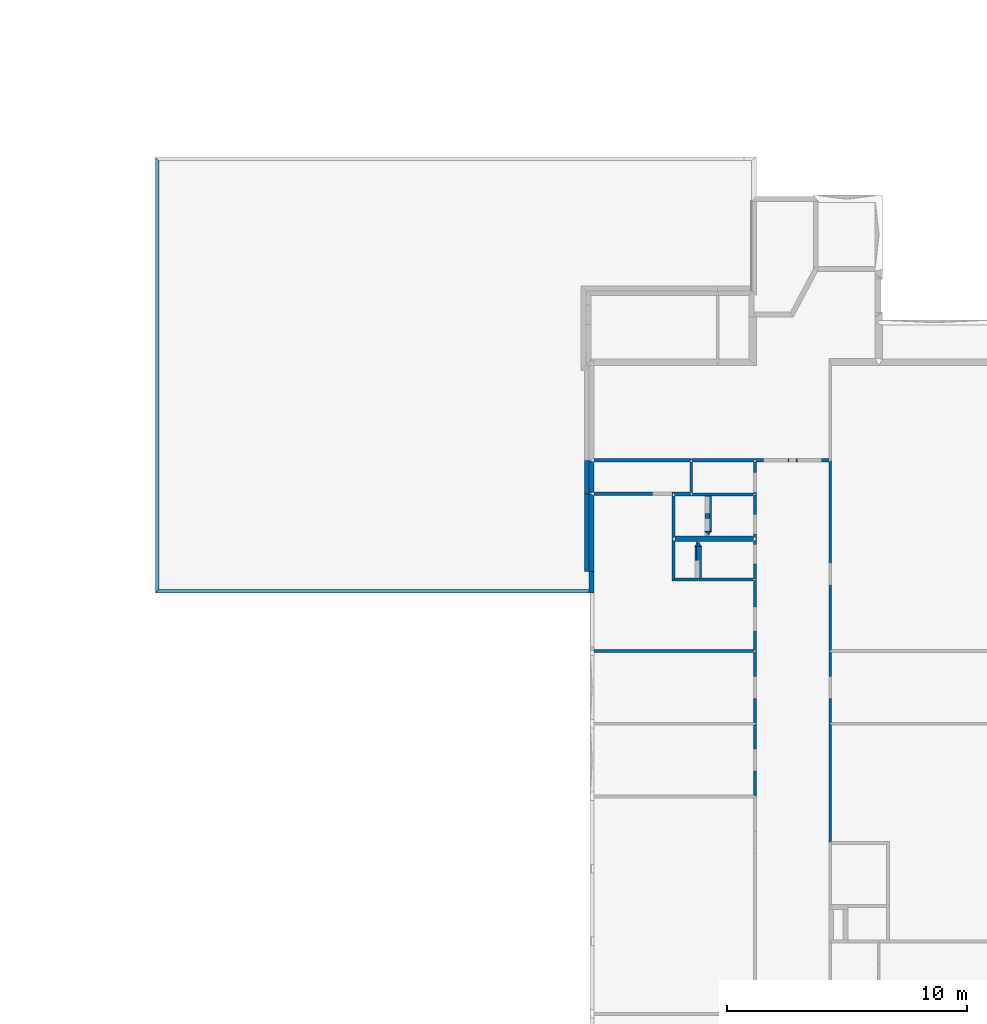
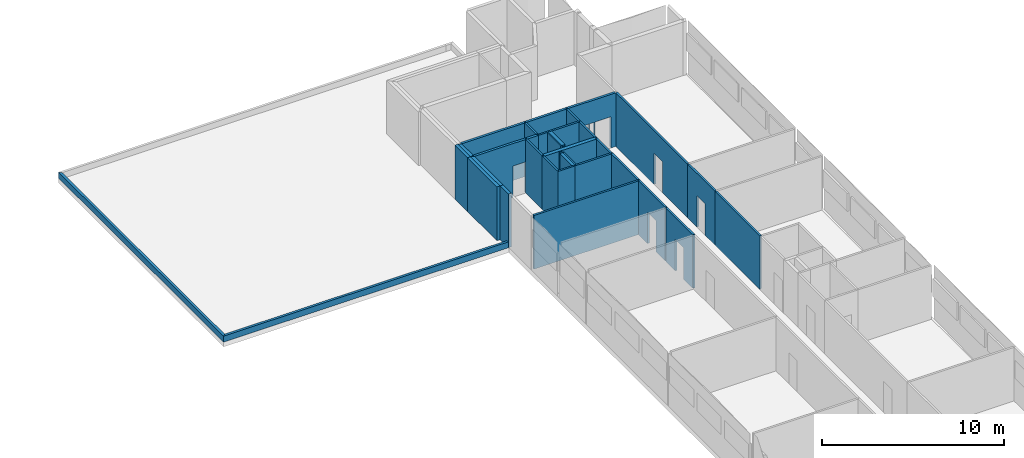
# One storey, part 3 of 72: 36 walls, 15 openings.
"""IFC2X3 building model written with IfcOpenShell, lengths in metres."""

from ifc_helpers import new_model, entity, si_unit, converted_unit, derived_unit, frame, origin_with_axes, place, context, project, spatial, polyline, outline, extrude, material, layer, layer_set, layer_usage, element, save


model = new_model("IFC2X3")

# Units and contexts
context_of_model_1 = context(None, 3, world=origin_with_axes())
context_of_model_2 = context(None, 3, world=origin_with_axes())
context_of_model_3 = context(None, 2, world=origin_with_axes())
context_of_model_4 = context(None, 3, world=origin_with_axes())
ifc_project = project(units=[si_unit("LENGTHUNIT", "METRE"), si_unit("AREAUNIT", "SQUARE_METRE"), si_unit("ELECTRICCURRENTUNIT", "AMPERE"), si_unit("ELECTRICVOLTAGEUNIT", "VOLT"), si_unit("ELECTRICRESISTANCEUNIT", "OHM"), si_unit("POWERUNIT", "WATT"), si_unit("MASSUNIT", "GRAM"), si_unit("SOLIDANGLEUNIT", "STERADIAN"), si_unit("THERMODYNAMICTEMPERATUREUNIT", "KELVIN"), si_unit("PRESSUREUNIT", "PASCAL"), si_unit("LUMINOUSFLUXUNIT", "LUMEN"), si_unit("ILLUMINANCEUNIT", "LUX"), si_unit("FREQUENCYUNIT", "HERTZ"), si_unit("VOLUMEUNIT", "CUBIC_METRE"), si_unit("TIMEUNIT", "SECOND"), derived_unit("VOLUMETRICFLOWRATEUNIT", [(si_unit("TIMEUNIT", "SECOND"), -1), (si_unit("VOLUMEUNIT", "CUBIC_METRE"), 1)]), derived_unit("THERMALTRANSMITTANCEUNIT", [(si_unit("AREAUNIT", "SQUARE_METRE"), -1), (si_unit("THERMODYNAMICTEMPERATUREUNIT", "KELVIN"), -1), (si_unit("POWERUNIT", "WATT"), 1)]), converted_unit("PLANEANGLEUNIT", "DEGREE", entity("IfcPlaneAngleMeasure", 57.29577951308232), si_unit("PLANEANGLEUNIT", "RADIAN"), dimensions=[0, 0, 0, 0, 0, 0, 0])], contexts=[context_of_model_1, context_of_model_2, context_of_model_3, context_of_model_4])

# Site, building, storey
site = spatial("IfcSite", under=ifc_project, CompositionType="ELEMENT")
building_placement = place(None, origin_with_axes())
building = spatial("IfcBuilding", under=site, at=building_placement, Name="200", CompositionType="ELEMENT")
storey_placement = place(building_placement, frame((0.0, 0.0, 15.68000030517578), z_axis=(0.0, 0.0, 1.0), x_axis=(1.0, 0.0, 0.0)))
storey = spatial("IfcBuildingStorey", under=building, at=storey_placement, Name="3.etasje", CompositionType="ELEMENT", Elevation=15.68000030517578)

# Walls
ifc_material_1 = material(Name="Layer-YV3 15 cm")
ifc_layer_1 = layer(ifc_material_1, 0.1500000059604645, ventilated=False)
ifc_layer_set_1 = layer_set([ifc_layer_1])
ifc_layer_usage_1 = layer_usage(ifc_layer_set_1, "AXIS2", "POSITIVE", 0.0)
wall_1_placement = place(storey_placement, frame((-24.49092864990234, 54.64245223999023, 0.0), z_axis=(0.0, 0.0, 1.0), x_axis=(-4.371138828673793e-08, -1.0, 0.0)))
element("IfcWallStandardCase", 1, at=wall_1_placement, inside=storey, material=ifc_layer_usage_1, Name="YV3 15 cm", context=context_of_model_1, shape_type="SweptSolid", body=[
    extrude(outline(polyline([(0.0, 0.0), (18.13259887695312, 1.058791184067875e-22), (17.98259735107422, 0.1499996185302741), (0.1500015258789088, 0.1499996185302766), (0.0, 0.0)])), frame((0.0, 0.0, 0.0), z_axis=(0.0, 0.0, 1.0), x_axis=(0.999999999999999, 4.371139009642039e-08, 0.0)), (0.0, 0.0, 1.0), 0.4),
])
wall_2_placement = place(storey_placement, frame((-24.49092864990234, 36.50985336303711, 0.0), z_axis=(0.0, 0.0, 1.0), x_axis=(1.0, 0.0, 0.0)))
element("IfcWallStandardCase", 2, at=wall_2_placement, inside=storey, material=ifc_layer_usage_1, Name="YV3 15 cm", context=context_of_model_1, shape_type="SweptSolid", body=[
    extrude(outline(polyline([(0.0, 0.0), (18.07922124862671, 0.0), (18.22922134399414, 0.1500015258789063), (0.1499996185302734, 0.1500015258789063), (0.0, 0.0)])), origin_with_axes(), (0.0, 0.0, 1.0), 0.4),
])
ifc_material_2 = material(Name="Layer-YV1 20.0cm")
ifc_layer_2 = layer(ifc_material_2, 0.2000045776367188, ventilated=False)
ifc_layer_set_2 = layer_set([ifc_layer_2])
ifc_layer_usage_2 = layer_usage(ifc_layer_set_2, "AXIS2", "POSITIVE", 0.0)
wall_3_placement = place(storey_placement, frame((-6.445881843566895, 37.41507339477539, 0.0), z_axis=(0.0, 0.0, 1.0), x_axis=(-4.371138828673793e-08, 1.0, 0.0)))
element("IfcWallStandardCase", 3, at=wall_3_placement, inside=storey, material=ifc_layer_usage_2, Name="YV1 20.0cm", context=context_of_model_1, shape_type="SweptSolid", body=[
    extrude(outline(polyline([(0.0, 0.0), (3.228466033935543, 0.0), (3.228466033935543, 0.1999998092651369), (-5.501640044481945e-16, 0.1999998092651369), (0.0, 0.0)])), frame((0.0, 0.0, 0.0), z_axis=(0.0, 0.0, 1.0), x_axis=(0.999999999999999, -4.371139009142383e-08, 0.0)), (0.0, 0.0, 1.0), 3.6),
])
wall_4_placement = place(storey_placement, frame((-6.445881843566895, 40.64353942871094, 0.0), z_axis=(0.0, 0.0, 1.0), x_axis=(-4.371138828673793e-08, 1.0, 0.0)))
element("IfcWallStandardCase", 4, at=wall_4_placement, inside=storey, material=ifc_layer_usage_2, Name="YV1 20.0cm", context=context_of_model_1, shape_type="SweptSolid", body=[
    extrude(outline(polyline([(0.0, 0.0), (1.393562316894533, 0.0), (1.393562316894532, 0.1999998092651369), (-5.85396066919635e-16, 0.1999998092651369), (0.0, 0.0)])), frame((0.0, 0.0, 0.0), z_axis=(0.0, 0.0, 1.0), x_axis=(0.999999999999999, -4.371139026758432e-08, 0.0)), (0.0, 0.0, 1.0), 3.6),
])
ifc_material_3 = material()
ifc_layer_3 = layer(ifc_material_3, 0.121002197265625, ventilated=False)
ifc_layer_set_3 = layer_set([ifc_layer_3])
ifc_layer_usage_3 = layer_usage(ifc_layer_set_3, "AXIS2", "POSITIVE", 0.0)
wall_5_placement = place(storey_placement, frame((3.517215490341187, 31.08137130737305, 0.0), z_axis=(0.0, 0.0, 1.0), x_axis=(-4.371138828673793e-08, -1.0, 0.0)))
element("IfcWallStandardCase", 5, at=wall_5_placement, inside=storey, material=ifc_layer_usage_3, context=context_of_model_1, shape_type="SweptSolid", body=[
    extrude(outline(polyline([(0.0, 0.0), (4.954126358032224, -2.646977960169689e-23), (4.892126083374019, 0.1205992698669437), (0.06030082702636621, 0.1205992698669438), (0.0, 0.0)])), frame((0.0, 0.0, 0.0), z_axis=(0.0, 0.0, 1.0), x_axis=(0.9999999999999991, 4.371139001534688e-08, 0.0)), (0.0, 0.0, 1.0), 3.6),
])

# Wall, opening
wall_6_placement = place(storey_placement, frame((3.517215490341187, 34.09809875488281, 0.0), z_axis=(0.0, 0.0, 1.0), x_axis=(-4.371138828673793e-08, -1.0, 0.0)))
wall_6 = element("IfcWallStandardCase", 6, at=wall_6_placement, inside=storey, material=ifc_layer_usage_3, context=context_of_model_1, shape_type="SweptSolid", body=[
    extrude(outline(polyline([(0.0, 0.0), (3.016727447509765, 0.0), (2.956426620483396, 0.1205992698669435), (0.06280899047851819, 0.1205992698669435), (0.0, 0.0)])), frame((0.0, 0.0, 0.0), z_axis=(0.0, 0.0, 1.0), x_axis=(0.999999999999999, 4.371138992336804e-08, 0.0)), (0.0, 0.0, 1.0), 3.6),
])
opening_1_placement = place(wall_6_placement, frame((1.045032495949144, 0.1205993155467664, 0.0), z_axis=(0.0, 0.0, 1.0), x_axis=(1.0, 0.0, 0.0)))
element("IfcOpeningElement", 7, at=opening_1_placement, cuts=wall_6, context=context_of_model_1, shape_type="SweptSolid", body=[
    extrude(outline(polyline([(0.0, 0.0), (2.099999904632568, 0.0), (2.099999904632568, 0.9145469665527356), (0.0, 0.9145469665527356), (0.0, 0.0)])), frame((0.0, 0.0, 0.0), z_axis=(-4.37113901918186e-08, 0.9999999999999991, 0.0), x_axis=(0.0, 0.0, 1.0)), (0.0, -4.371139019181861e-08, -0.9999999999999991), 0.1205992698669434),
])

wall_7_placement = place(storey_placement, frame((3.517215490341187, 41.96172714233398, 0.0), z_axis=(0.0, 0.0, 1.0), x_axis=(-4.371138828673793e-08, -1.0, 0.0)))
wall_7 = element("IfcWallStandardCase", 8, at=wall_7_placement, inside=storey, material=ifc_layer_usage_3, context=context_of_model_1, shape_type="SweptSolid", body=[
    extrude(outline(polyline([(0.0, 0.0), (7.863628387451174, 0.0), (7.800815582275395, 0.1205992698669433), (-0.07537460327148193, 0.1205992698669437), (0.0, 0.0)])), frame((0.0, 0.0, 0.0), z_axis=(0.0, 0.0, 1.0), x_axis=(0.999999999999999, 4.371139002712389e-08, 0.0)), (0.0, 0.0, 1.0), 3.6),
])
opening_2_placement = place(wall_7_placement, frame((4.195827478859293, 0.1205994532723951, 0.0), z_axis=(0.0, 0.0, 1.0), x_axis=(1.0, 0.0, 0.0)))
element("IfcOpeningElement", 9, at=opening_2_placement, cuts=wall_7, context=context_of_model_1, shape_type="SweptSolid", body=[
    extrude(outline(polyline([(0.0, 0.0), (2.099999904632568, 0.0), (2.099999904632568, 0.9145507812500011), (0.0, 0.9145507812500011), (0.0, 0.0)])), frame((0.0, 0.0, 0.0), z_axis=(-4.371138995971891e-08, 0.999999999999999, 0.0), x_axis=(0.0, 0.0, 1.0)), (0.0, -4.371138995971892e-08, -0.9999999999999991), 0.1205992698669434),
])

# Walls
ifc_material_4 = material()
ifc_layer_4 = layer(ifc_material_4, 0.1205999851226807, ventilated=False)
ifc_layer_set_4 = layer_set([ifc_layer_4])
ifc_layer_usage_4 = layer_usage(ifc_layer_set_4, "AXIS2", "POSITIVE", 0.0)
wall_8_placement = place(storey_placement, frame((-2.20166802406311, 40.54693603515625, 0.0), z_axis=(0.0, 0.0, 1.0), x_axis=(1.0, 0.0, 0.0)))
element("IfcWallStandardCase", 10, at=wall_8_placement, inside=storey, material=ifc_layer_usage_4, context=context_of_model_1, shape_type="SweptSolid", body=[
    extrude(outline(polyline([(0.0, 0.0), (0.6402485370635986, 0.0), (0.7005481719970703, 0.1205978393554688), (0.06030011177062988, 0.1205978393554688), (0.0, 0.0)])), origin_with_axes(), (0.0, 0.0, 1.0), 3.6),
])
wall_9_placement = place(storey_placement, frame((-1.440820217132568, 40.54693603515625, 0.0), z_axis=(0.0, 0.0, 1.0), x_axis=(1.0, 0.0, 0.0)))
element("IfcWallStandardCase", 11, at=wall_9_placement, inside=storey, material=ifc_layer_usage_3, context=context_of_model_1, shape_type="SweptSolid", body=[
    extrude(outline(polyline([(0.0, 0.0), (1.825047940015793, 0.0), (1.82504802942276, 0.1205978393554688), (-0.06029963493347168, 0.1205978393554688), (0.0, 0.0)])), origin_with_axes(), (0.0, 0.0, 1.0), 3.6),
])

# Wall, opening
wall_10_placement = place(storey_placement, frame((0.5048271417617798, 40.60723495483398, 0.0), z_axis=(0.0, 0.0, 1.0), x_axis=(-4.371138828673793e-08, 1.0, 0.0)))
wall_10 = element("IfcWallStandardCase", 12, at=wall_10_placement, inside=storey, material=ifc_layer_usage_3, context=context_of_model_1, shape_type="SweptSolid", body=[
    extrude(outline(polyline([(0.0, 0.0), (1.354492187500002, 6.617444900424221e-24), (1.354492187499996, 0.1205993294715881), (0.0602989196777293, 0.1205993294715881), (0.0, 0.0)])), frame((0.0, 0.0, 0.0), z_axis=(0.0, 0.0, 1.0), x_axis=(0.999999999999999, -4.371139002339245e-08, 0.0)), (0.0, 0.0, 1.0), 3.6),
])
opening_3_placement = place(wall_10_placement, frame((0.09959412148249669, 0.1205993251181907, 0.0), z_axis=(0.0, 0.0, 1.0), x_axis=(1.0, 0.0, 0.0)))
element("IfcOpeningElement", 13, at=opening_3_placement, cuts=wall_10, context=context_of_model_1, shape_type="SweptSolid", body=[
    extrude(outline(polyline([(0.0, 0.0), (2.099999904632568, 0.0), (2.099999904632568, 0.8140487670898446), (0.0, 0.8140487670898446), (0.0, 0.0)])), frame((0.0, 0.0, 0.0), z_axis=(4.371139003008114e-08, 0.999999999999999, 0.0), x_axis=(0.0, 0.0, 1.0)), (0.0, 4.371139003008115e-08, -0.9999999999999992), 0.1205993294715881),
])

# Walls
ifc_material_5 = material()
ifc_layer_5 = layer(ifc_material_5, 0.1506895795464516, ventilated=False)
ifc_layer_set_5 = layer_set([ifc_layer_5])
ifc_layer_usage_5 = layer_usage(ifc_layer_set_5, "AXIS2", "POSITIVE", 0.0)
wall_11_placement = place(storey_placement, frame((0.4445274472236633, 42.11247634887695, 0.0), z_axis=(0.0, 0.0, 1.0), x_axis=(-1.0, -8.742277657347586e-08, 0.0)))
element("IfcWallStandardCase", 14, at=wall_11_placement, inside=storey, material=ifc_layer_usage_5, context=context_of_model_1, shape_type="SweptSolid", body=[
    extrude(outline(polyline([(0.0, 0.0), (2.646195471286774, 0.0), (2.585895359516144, 0.1507492065429677), (0.06029963493347169, 0.1507492065429648), (0.0, 0.0)])), frame((0.0, 0.0, 0.0), z_axis=(0.0, 0.0, 1.0), x_axis=(0.9999999999999961, -8.742278015910702e-08, 0.0)), (0.0, 0.0, 1.0), 3.6),
])
wall_12_placement = place(storey_placement, frame((-2.26196813583374, 41.96172714233398, 0.0), z_axis=(0.0, 0.0, 1.0), x_axis=(-4.371138828673793e-08, -1.0, 0.0)))
element("IfcWallStandardCase", 15, at=wall_12_placement, inside=storey, material=ifc_layer_usage_3, context=context_of_model_1, shape_type="SweptSolid", body=[
    extrude(outline(polyline([(0.0, 0.0), (1.242191314697267, 0.0), (1.294193267822268, 0.1206002235412599), (1.609640811228855e-15, 0.1206002235412599), (0.0, 0.0)])), frame((0.0, 0.0, 0.0), z_axis=(0.0, 0.0, 1.0), x_axis=(0.9999999999999991, 4.37113902162027e-08, 0.0)), (0.0, 0.0, 1.0), 3.6),
])
ifc_material_6 = material()
ifc_layer_6 = layer(ifc_material_6, 0.2000000029802322, ventilated=False)
ifc_layer_set_6 = layer_set([ifc_layer_6])
ifc_layer_usage_6 = layer_usage(ifc_layer_set_6, "AXIS2", "POSITIVE", 0.0)
wall_13_placement = place(storey_placement, frame((-2.880736112594605, 38.65560531616211, 0.0), z_axis=(0.0, 0.0, 1.0), x_axis=(1.0, 0.0, 0.0)))
element("IfcWallStandardCase", 16, at=wall_13_placement, inside=storey, material=ifc_layer_usage_6, context=context_of_model_1, shape_type="SweptSolid", body=[
    extrude(outline(polyline([(0.0, 0.0), (3.264963805675507, 0.0), (3.264963835477829, 0.2261276245117188), (0.0, 0.2261276245117188), (0.0, 0.0)])), origin_with_axes(), (0.0, 0.0, 1.0), 3.6),
])

# Wall, opening
wall_14_placement = place(storey_placement, frame((0.5048271417617798, 38.76866912841797, 0.0), z_axis=(0.0, 0.0, 1.0), x_axis=(-4.371138828673793e-08, 1.0, 0.0)))
wall_14 = element("IfcWallStandardCase", 17, at=wall_14_placement, inside=storey, material=ifc_layer_usage_3, context=context_of_model_1, shape_type="SweptSolid", body=[
    extrude(outline(polyline([(0.0, 0.0), (1.838565826416011, 0.0), (1.778266906738274, 0.1205994188785553), (0.1130638122558576, 0.1205994188785553), (0.0, 0.0)])), frame((0.0, 0.0, 0.0), z_axis=(0.0, 0.0, 1.0), x_axis=(0.999999999999999, -4.371138999110359e-08, 0.0)), (0.0, 0.0, 1.0), 3.6),
])
opening_4_placement = place(wall_14_placement, frame((0.1961708121563319, 0.1205994103036565, 0.0), z_axis=(0.0, 0.0, 1.0), x_axis=(1.0, 0.0, 0.0)))
element("IfcOpeningElement", 18, at=opening_4_placement, cuts=wall_14, context=context_of_model_1, shape_type="SweptSolid", body=[
    extrude(outline(polyline([(0.0, 0.0), (2.099999904632568, 0.0), (2.099999904632568, 0.8140525817871032), (0.0, 0.8140525817871032), (0.0, 0.0)])), frame((0.0, 0.0, 0.0), z_axis=(4.371139004209337e-08, 0.999999999999999, 0.0), x_axis=(0.0, 0.0, 1.0)), (0.0, 4.371139004209338e-08, -0.9999999999999992), 0.1205994188785553),
])

# Wall, openings
wall_15_placement = place(storey_placement, frame((-1.640820384025574, 40.66753387451172, 0.0), z_axis=(0.0, 0.0, 1.0), x_axis=(7.549790126404332e-08, -1.0, 0.0)))
wall_15 = element("IfcWallStandardCase", 19, at=wall_15_placement, inside=storey, material=ifc_layer_usage_6, context=context_of_model_1, shape_type="SweptSolid", body=[
    extrude(outline(polyline([(0.0, 0.0), (1.585800170898438, 0.0), (1.78580094887249, 0.2000000326490664), (0.1205978543900677, 0.2000001578273087), (0.0, 0.0)])), frame((0.0, 0.0, 0.0), z_axis=(0.0, 0.0, 1.0), x_axis=(1.0, -3.249416192609171e-10, 0.0)), (0.0, 0.0, 1.0), 3.6),
])
opening_5_placement = place(wall_15_placement, frame((1.053325668175759, 0.2000000873691306, 0.0), z_axis=(0.0, 0.0, 1.0), x_axis=(1.0, 0.0, 0.0)))
element("IfcOpeningElement", 20, at=opening_5_placement, cuts=wall_15, context=context_of_model_1, shape_type="SweptSolid", body=[
    extrude(outline(polyline([(0.0, 0.0), (2.099999904632568, 0.0), (2.099999904632568, 0.7034988403320334), (0.0, 0.7034988403320334), (0.0, 0.0)])), frame((0.0, 0.0, 0.0), z_axis=(7.549789974315231e-08, 0.9999999999999971, 0.0), x_axis=(0.0, 0.0, 1.0)), (0.0, 7.549789974315232e-08, -0.9999999999999973), 0.2000000029802322),
])
opening_6_placement = place(wall_15_placement, frame((0.1297874601679467, 0.2000001570943255, 0.0), z_axis=(0.0, 0.0, 1.0), x_axis=(1.0, 0.0, 0.0)))
element("IfcOpeningElement", 21, at=opening_6_placement, cuts=wall_15, context=context_of_model_1, shape_type="SweptSolid", body=[
    extrude(outline(polyline([(0.0, 0.0), (2.099999904632568, 0.0), (2.099999904632568, 0.7211418151855489), (0.0, 0.7211418151855489), (0.0, 0.0)])), frame((0.0, 0.0, 0.0), z_axis=(7.549789983835708e-08, 0.9999999999999972, 0.0), x_axis=(0.0, 0.0, 1.0)), (0.0, 7.549789983835706e-08, -0.999999999999997), 0.2000000029802322),
])

# Walls
wall_16_placement = place(storey_placement, frame((-1.440820217132568, 38.88173294067383, 0.0), z_axis=(0.0, 0.0, 1.0), x_axis=(-1.0, -8.742277657347586e-08, 0.0)))
element("IfcWallStandardCase", 22, at=wall_16_placement, inside=storey, material=ifc_layer_usage_6, context=context_of_model_1, shape_type="SweptSolid", body=[
    extrude(outline(polyline([(0.0, 0.0), (0.1205992698669432, 0.0), (-0.07940077781678087, 0.2000007629394461), (0.2000000476837074, 0.2000007629394617), (0.0, 0.0)])), frame((0.0, 0.0, 0.0), z_axis=(0.0, 0.0, -1.0), x_axis=(0.9999999999999962, -8.742273804782444e-08, 0.0)), (0.0, 0.0, -1.0), 3.6),
])
wall_17_placement = place(storey_placement, frame((-1.361419439315796, 39.08173370361328, 0.0), z_axis=(0.0, 0.0, 1.0), x_axis=(-4.371138828673793e-08, 1.0, 0.0)))
element("IfcWallStandardCase", 23, at=wall_17_placement, inside=storey, material=ifc_layer_usage_6, context=context_of_model_1, shape_type="SweptSolid", body=[
    extrude(outline(polyline([(0.0, 0.0), (1.585800170898432, 0.0), (1.465202331542959, 0.2000000476837159), (-0.2000007629394572, 0.2000000476837158), (0.0, 0.0)])), frame((0.0, 0.0, 0.0), z_axis=(0.0, 0.0, 1.0), x_axis=(0.999999999999999, -4.371138998988838e-08, 0.0)), (0.0, 0.0, 1.0), 3.6),
])
ifc_material_7 = material()
ifc_layer_7 = layer(ifc_material_7, 0.1518646478652954, ventilated=False)
ifc_layer_set_7 = layer_set([ifc_layer_7])
ifc_layer_usage_7 = layer_usage(ifc_layer_set_7, "AXIS2", "POSITIVE", 0.0)
wall_18_placement = place(storey_placement, frame((-2.26196813583374, 40.71953582763672, 0.0), z_axis=(0.0, 0.0, 1.0), x_axis=(-1.0, -8.742277657347586e-08, 0.0)))
element("IfcWallStandardCase", 24, at=wall_18_placement, inside=storey, material=ifc_layer_usage_7, context=context_of_model_1, shape_type="SweptSolid", body=[
    extrude(outline(polyline([(0.0, 0.0), (0.6760985851287841, 6.617444900424221e-24), (0.6187679767608637, 0.1725997924804661), (-0.06030011177063068, 0.1725997924804677), (0.0, 0.0)])), frame((0.0, 0.0, 0.0), z_axis=(0.0, 0.0, 1.0), x_axis=(0.9999999999999962, -8.742278214240656e-08, 0.0)), (0.0, 0.0, 1.0), 3.6),
])
ifc_material_8 = material()
ifc_layer_8 = layer(ifc_material_8, 0.1146612167358398, ventilated=False)
ifc_layer_set_8 = layer_set([ifc_layer_8])
ifc_layer_usage_8 = layer_usage(ifc_layer_set_8, "AXIS2", "POSITIVE", 0.0)
wall_19_placement = place(storey_placement, frame((-2.995397329330444, 40.56753921508789, 0.0), z_axis=(0.0, 0.0, 1.0), x_axis=(-4.371138828673793e-08, -1.0, 0.0)))
element("IfcWallStandardCase", 25, at=wall_19_placement, inside=storey, material=ifc_layer_usage_8, context=context_of_model_1, shape_type="SweptSolid", body=[
    extrude(outline(polyline([(0.0, 0.0), (1.798870086669917, 0.0), (1.685806274414053, 0.1146612167358395), (0.02060317993163677, 0.1146612167358397), (0.0, 0.0)])), frame((0.0, 0.0, 0.0), z_axis=(0.0, 0.0, 1.0), x_axis=(0.999999999999999, 4.371138995894988e-08, 0.0)), (0.0, 0.0, 1.0), 3.6),
])
wall_20_placement = place(storey_placement, frame((-2.995397329330444, 37.01464462280273, 0.0), z_axis=(0.0, 0.0, 1.0), x_axis=(1.0, 0.0, 0.0)))
element("IfcWallStandardCase", 26, at=wall_20_placement, inside=storey, material=ifc_layer_usage_4, context=context_of_model_1, shape_type="SweptSolid", body=[
    extrude(outline(polyline([(0.0, 0.0), (1.079642295837402, 0.0), (1.019342064857483, 0.1206016540527344), (0.1146612167358398, 0.1206016540527344), (0.0, 0.0)])), origin_with_axes(), (0.0, 0.0, 1.0), 3.6),
])
wall_21_placement = place(storey_placement, frame((-1.776055216789246, 37.01464462280273, 0.0), z_axis=(0.0, 0.0, 1.0), x_axis=(-4.371138828673793e-08, 1.0, 0.0)))
element("IfcWallStandardCase", 27, at=wall_21_placement, inside=storey, material=ifc_layer_usage_6, context=context_of_model_1, shape_type="SweptSolid", body=[
    extrude(outline(polyline([(0.0, 0.0), (1.440959930419923, 0.0), (1.64096069335938, 0.2000000476837158), (0.1206016540527377, 0.2000000476837159), (0.0, 0.0)])), frame((0.0, 0.0, 0.0), z_axis=(0.0, 0.0, 1.0), x_axis=(0.9999999999999991, -4.371138997702297e-08, 0.0)), (0.0, 0.0, 1.0), 3.6),
])
wall_22_placement = place(storey_placement, frame((-1.976055264472961, 38.65560531616211, 0.0), z_axis=(0.0, 0.0, 1.0), x_axis=(1.0, 0.0, 0.0)))
element("IfcWallStandardCase", 28, at=wall_22_placement, inside=storey, material=ifc_layer_usage_6, context=context_of_model_1, shape_type="SweptSolid", body=[
    extrude(outline(polyline([(0.0, 0.0), (0.1206003427505493, 0.0), (-0.0793997049331665, 0.2000007629394531), (0.2000000476837158, 0.2000007629394531), (0.0, 0.0)])), frame((0.0, 0.0, 0.0), z_axis=(0.0, 0.0, -1.0), x_axis=(1.0, 0.0, 0.0)), (0.0, 0.0, -1.0), 3.6),
])

# Wall, opening
wall_23_placement = place(storey_placement, frame((-2.055454969406128, 38.45560455322266, 0.0), z_axis=(0.0, 0.0, 1.0), x_axis=(-4.371138828673793e-08, -1.0, 0.0)))
wall_23 = element("IfcWallStandardCase", 29, at=wall_23_placement, inside=storey, material=ifc_layer_usage_6, context=context_of_model_1, shape_type="SweptSolid", body=[
    extrude(outline(polyline([(0.0, 0.0), (1.440959930419923, 0.0), (1.320358276367192, 0.2000000476837157), (-0.2000007629394494, 0.2000000476837156), (0.0, 0.0)])), frame((0.0, 0.0, 0.0), z_axis=(0.0, 0.0, 1.0), x_axis=(0.9999999999999991, 4.371138997702297e-08, 0.0)), (0.0, 0.0, 1.0), 3.6),
])
opening_7_placement = place(wall_23_placement, frame((0.5801658542948331, 0.2000000730435718, 0.0), z_axis=(0.0, 0.0, 1.0), x_axis=(1.0, 0.0, 0.0)))
element("IfcOpeningElement", 30, at=opening_7_placement, cuts=wall_23, context=context_of_model_1, shape_type="SweptSolid", body=[
    extrude(outline(polyline([(0.0, 0.0), (2.099999904632568, 0.0), (2.099999904632568, 0.7268714904785165), (0.0, 0.7268714904785165), (0.0, 0.0)])), frame((0.0, 0.0, 0.0), z_axis=(-4.37113894535054e-08, 0.999999999999999, 0.0), x_axis=(0.0, 0.0, 1.0)), (0.0, -4.371138945350541e-08, -0.9999999999999992), 0.2000000029802322),
])

# Wall
wall_24_placement = place(storey_placement, frame((-1.915755033493042, 37.01464462280273, 0.0), z_axis=(0.0, 0.0, 1.0), x_axis=(1.0, 0.0, 0.0)))
element("IfcWallStandardCase", 31, at=wall_24_placement, inside=storey, material=ifc_layer_usage_4, context=context_of_model_1, shape_type="SweptSolid", body=[
    extrude(outline(polyline([(0.0, 0.0), (2.299982637166977, 0.0), (2.299982726573944, 0.1206016540527344), (0.06030011177062988, 0.1206016540527344), (0.0, 0.0)])), origin_with_axes(), (0.0, 0.0, 1.0), 3.6),
])

# Wall, opening
wall_25_placement = place(storey_placement, frame((0.5048271417617798, 37.07494354248047, 0.0), z_axis=(0.0, 0.0, 1.0), x_axis=(-4.371138828673793e-08, 1.0, 0.0)))
wall_25 = element("IfcWallStandardCase", 32, at=wall_25_placement, inside=storey, material=ifc_layer_usage_3, context=context_of_model_1, shape_type="SweptSolid", body=[
    extrude(outline(polyline([(0.0, 0.0), (1.693725585937502, 0.0), (1.580661773681639, 0.1205994486808777), (0.06030273437499681, 0.1205994486808776), (0.0, 0.0)])), frame((0.0, 0.0, 0.0), z_axis=(0.0, 0.0, 1.0), x_axis=(0.9999999999999991, -4.371139004581126e-08, 0.0)), (0.0, 0.0, 1.0), 3.6),
])
opening_8_placement = place(wall_25_placement, frame((0.6459007315899257, 0.1205994204476589, 0.0), z_axis=(0.0, 0.0, 1.0), x_axis=(1.0, 0.0, 0.0)))
element("IfcOpeningElement", 33, at=opening_8_placement, cuts=wall_25, context=context_of_model_1, shape_type="SweptSolid", body=[
    extrude(outline(polyline([(0.0, 0.0), (2.099999904632568, 0.0), (2.099999904632568, 0.8140000000000008), (0.0, 0.8140000000000008), (0.0, 0.0)])), frame((0.0, 0.0, 0.0), z_axis=(4.371139002217741e-08, 0.9999999999999991, 0.0), x_axis=(0.0, 0.0, 1.0)), (0.0, 4.371139002217741e-08, -0.999999999999999), 0.1205994486808777),
])

# Walls
wall_26_placement = place(storey_placement, frame((-2.995397329330444, 38.76866912841797, 0.0), z_axis=(0.0, 0.0, 1.0), x_axis=(-4.371138828673793e-08, -1.0, 0.0)))
element("IfcWallStandardCase", 34, at=wall_26_placement, inside=storey, material=ifc_layer_usage_8, context=context_of_model_1, shape_type="SweptSolid", body=[
    extrude(outline(polyline([(0.0, 0.0), (1.754024505615236, 0.0), (1.633422851562498, 0.1146612167358397), (0.1130638122558556, 0.1146612167358396), (0.0, 0.0)])), frame((0.0, 0.0, 0.0), z_axis=(0.0, 0.0, 1.0), x_axis=(0.9999999999999991, 4.371138999459515e-08, 0.0)), (0.0, 0.0, 1.0), 3.6),
])
ifc_material_9 = material()
ifc_layer_9 = layer(ifc_material_9, 0.1260013580322266, ventilated=False)
ifc_layer_set_9 = layer_set([ifc_layer_9])
ifc_layer_usage_9 = layer_usage(ifc_layer_set_9, "AXIS2", "POSITIVE", 0.0)
wall_27_placement = place(storey_placement, frame((-6.245882511138916, 34.0356559753418, 0.0), z_axis=(0.0, 0.0, 1.0), x_axis=(1.0, 0.0, 0.0)))
element("IfcWallStandardCase", 35, at=wall_27_placement, inside=storey, material=ifc_layer_usage_9, context=context_of_model_1, shape_type="SweptSolid", body=[
    extrude(outline(polyline([(0.0, 0.0), (6.630110114812851, 0.0), (6.630110114812851, 0.1256217956542969), (4.76837158203125e-07, 0.1256217956542969), (0.0, 0.0)])), origin_with_axes(), (0.0, 0.0, 1.0), 3.6),
])

# Wall, opening
wall_28_placement = place(storey_placement, frame((0.5048271417617798, 34.09846496582031, 0.0), z_axis=(0.0, 0.0, 1.0), x_axis=(-4.371138828673793e-08, 1.0, 0.0)))
wall_28 = element("IfcWallStandardCase", 36, at=wall_28_placement, inside=storey, material=ifc_layer_usage_3, context=context_of_model_1, shape_type="SweptSolid", body=[
    extrude(outline(polyline([(0.0, 0.0), (2.97647857666016, 0.0), (2.916179656982425, 0.1205995380878448), (0.06281280517578128, 0.1205995380878448), (0.0, 0.0)])), frame((0.0, 0.0, 0.0), z_axis=(0.0, 0.0, 1.0), x_axis=(0.999999999999999, -4.371138998615916e-08, 0.0)), (0.0, 0.0, 1.0), 3.6),
])
opening_9_placement = place(wall_28_placement, frame((0.8287658744121984, 0.1205995018613366, 0.0), z_axis=(0.0, 0.0, 1.0), x_axis=(1.0, 0.0, 0.0)))
element("IfcOpeningElement", 37, at=opening_9_placement, cuts=wall_28, context=context_of_model_1, shape_type="SweptSolid", body=[
    extrude(outline(polyline([(0.0, 0.0), (2.099999904632568, 0.0), (2.099999904632568, 1.010005950927736), (0.0, 1.010005950927736), (0.0, 0.0)])), frame((0.0, 0.0, 0.0), z_axis=(4.371139006500683e-08, 0.999999999999999, 0.0), x_axis=(0.0, 0.0, 1.0)), (0.0, 4.371139006500683e-08, -0.9999999999999992), 0.1205995380878449),
])

wall_29_placement = place(storey_placement, frame((-2.938066720962524, 40.71953582763672, 0.0), z_axis=(0.0, 0.0, 1.0), x_axis=(-1.0, -8.742277657347586e-08, 0.0)))
wall_29 = element("IfcWallStandardCase", 38, at=wall_29_placement, inside=storey, material=ifc_layer_usage_7, context=context_of_model_1, shape_type="SweptSolid", body=[
    extrude(outline(polyline([(0.0, 0.0), (3.307815313339233, 5.293955920339377e-23), (3.307815313339233, 0.1519966125488287), (0.05733060836792005, 0.1519966125488248), (0.0, 0.0)])), frame((0.0, 0.0, 0.0), z_axis=(0.0, 0.0, 1.0), x_axis=(0.9999999999999962, -8.742277963716434e-08, 0.0)), (0.0, 0.0, 1.0), 3.6),
])
opening_10_placement = place(wall_29_placement, frame((0.05824448006958249, 0.1519966074569297, 0.0), z_axis=(0.0, 0.0, 1.0), x_axis=(1.0, 0.0, 0.0)))
element("IfcOpeningElement", 39, at=opening_10_placement, cuts=wall_29, context=context_of_model_1, shape_type="SweptSolid", body=[
    extrude(outline(polyline([(0.0, 0.0), (2.099999904632568, 0.0), (2.099999904632568, 0.8099999427795411), (0.0, 0.8099999427795411), (0.0, 0.0)])), frame((0.0, 0.0, 0.0), z_axis=(8.7422772047241e-08, 0.9999999999999961, 0.0), x_axis=(0.0, 0.0, 1.0)), (0.0, 8.742277204724101e-08, -0.9999999999999963), 0.1519966125488281),
])

# Walls
wall_30_placement = place(storey_placement, frame((-6.445881843566895, 40.64353942871094, 0.0), z_axis=(0.0, 0.0, 1.0), x_axis=(-4.371138828673793e-08, -1.0, 0.0)))
element("IfcWallStandardCase", 40, at=wall_30_placement, inside=storey, material=ifc_layer_usage_6, context=context_of_model_1, shape_type="SweptSolid", body=[
    extrude(outline(polyline([(0.0, 0.0), (3.228466033935543, 0.0), (3.228466033935544, 0.1999998092651369), (0.0760002136230475, 0.199999809265137), (0.0, 0.0)])), frame((0.0, 0.0, 0.0), z_axis=(0.0, 0.0, 1.0), x_axis=(0.999999999999999, 4.371139009142383e-08, 0.0)), (0.0, 0.0, 1.0), 3.6),
])
wall_31_placement = place(storey_placement, frame((-6.445881843566895, 37.41507339477539, 0.0), z_axis=(0.0, 0.0, 1.0), x_axis=(-4.371138828673793e-08, -1.0, 0.0)))
element("IfcWallStandardCase", 41, at=wall_31_placement, inside=storey, material=ifc_layer_usage_6, context=context_of_model_1, shape_type="SweptSolid", body=[
    extrude(outline(polyline([(0.0, 0.0), (0.9052200317382824, 0.0), (0.9052200317382828, 0.1999998092651369), (5.376322529096018e-16, 0.1999998092651369), (0.0, 0.0)])), frame((0.0, 0.0, 0.0), z_axis=(0.0, 0.0, 1.0), x_axis=(0.999999999999999, 4.371139002876501e-08, 0.0)), (0.0, 0.0, 1.0), 3.6),
])
wall_32_placement = place(storey_placement, frame((-2.20166802406311, 42.11247634887695, 0.0), z_axis=(0.0, 0.0, 1.0), x_axis=(-1.0, -8.742277657347586e-08, 0.0)))
element("IfcWallStandardCase", 42, at=wall_32_placement, inside=storey, material=ifc_layer_usage_5, context=context_of_model_1, shape_type="SweptSolid", body=[
    extrude(outline(polyline([(0.0, 0.0), (4.044214010238648, 0.0), (4.044214010238648, 0.1507492065429693), (0.06030011177063029, 0.1507492065429709), (0.0, 0.0)])), frame((0.0, 0.0, 0.0), z_axis=(0.0, 0.0, 1.0), x_axis=(0.9999999999999962, -8.742277966982903e-08, 0.0)), (0.0, 0.0, 1.0), 3.6),
])
wall_33_placement = place(storey_placement, frame((-6.445881843566895, 42.03710174560547, 0.0), z_axis=(0.0, 0.0, 1.0), x_axis=(-4.371138828673793e-08, -1.0, 0.0)))
element("IfcWallStandardCase", 43, at=wall_33_placement, inside=storey, material=ifc_layer_usage_6, context=context_of_model_1, shape_type="SweptSolid", body=[
    extrude(outline(polyline([(0.0, 0.0), (1.393562316894533, 0.0), (1.317565917968752, 0.1999998092651371), (0.07537460327148506, 0.1999998092651372), (0.0, 0.0)])), frame((0.0, 0.0, 0.0), z_axis=(0.0, 0.0, 1.0), x_axis=(0.999999999999999, 4.371139026758432e-08, 0.0)), (0.0, 0.0, 1.0), 3.6),
])

# Wall, opening
wall_34_placement = place(storey_placement, frame((0.5048271417617798, 31.08193206787109, 0.0), z_axis=(0.0, 0.0, 1.0), x_axis=(-4.371138828673793e-08, 1.0, 0.0)))
wall_34 = element("IfcWallStandardCase", 44, at=wall_34_placement, inside=storey, material=ifc_layer_usage_3, context=context_of_model_1, shape_type="SweptSolid", body=[
    extrude(outline(polyline([(0.0, 0.0), (3.016532897949222, -2.646977960169689e-23), (2.953723907470707, 0.1205995380878448), (0.0602989196777344, 0.1205995380878448), (0.0, 0.0)])), frame((0.0, 0.0, 0.0), z_axis=(0.0, 0.0, 1.0), x_axis=(0.999999999999999, -4.371139001567375e-08, 0.0)), (0.0, 0.0, 1.0), 3.6),
])
opening_11_placement = place(wall_34_placement, frame((1.045455937888761, 0.1205994923895127, 0.0), z_axis=(0.0, 0.0, 1.0), x_axis=(1.0, 0.0, 0.0)))
element("IfcOpeningElement", 45, at=opening_11_placement, cuts=wall_34, context=context_of_model_1, shape_type="SweptSolid", body=[
    extrude(outline(polyline([(0.0, 0.0), (2.099999904632568, 0.0), (2.099999904632568, 0.9145469665527356), (0.0, 0.9145469665527356), (0.0, 0.0)])), frame((0.0, 0.0, 0.0), z_axis=(4.371139007042264e-08, 0.9999999999999991, 0.0), x_axis=(0.0, 0.0, 1.0)), (0.0, 4.371139007042265e-08, -0.9999999999999991), 0.1205995380878449),
])

wall_35_placement = place(storey_placement, frame((0.5048271417617798, 28.05381011962891, 0.0), z_axis=(0.0, 0.0, 1.0), x_axis=(-4.371138828673793e-08, 1.0, 0.0)))
wall_35 = element("IfcWallStandardCase", 46, at=wall_35_placement, inside=storey, material=ifc_layer_usage_3, context=context_of_model_1, shape_type="SweptSolid", body=[
    extrude(outline(polyline([(0.0, 0.0), (3.028121948242188, -2.646977960169689e-23), (2.967821121215821, 0.1205995976924896), (0.06029891967773535, 0.1205995976924896), (0.0, 0.0)])), frame((0.0, 0.0, 0.0), z_axis=(0.0, 0.0, 1.0), x_axis=(0.999999999999999, -4.37113900000163e-08, 0.0)), (0.0, 0.0, 1.0), 3.6),
])
opening_12_placement = place(wall_35_placement, frame((1.059303288962983, 0.1205995513888705, 0.0), z_axis=(0.0, 0.0, 1.0), x_axis=(1.0, 0.0, 0.0)))
element("IfcOpeningElement", 47, at=opening_12_placement, cuts=wall_35, context=context_of_model_1, shape_type="SweptSolid", body=[
    extrude(outline(polyline([(0.0, 0.0), (2.099999904632568, 0.0), (2.099999904632568, 0.9145507812500011), (0.0, 0.9145507812500011), (0.0, 0.0)])), frame((0.0, 0.0, 0.0), z_axis=(4.371139002041664e-08, 0.999999999999999, 0.0), x_axis=(0.0, 0.0, 1.0)), (0.0, 4.371139002041664e-08, -0.9999999999999991), 0.1205995976924896),
])

# Wall, openings
wall_36_placement = place(storey_placement, frame((3.517216205596924, 42.11247634887695, 0.0), z_axis=(0.0, 0.0, 1.0), x_axis=(-1.0, -8.742277657347586e-08, 0.0)))
wall_36 = element("IfcWallStandardCase", 48, at=wall_36_placement, inside=storey, material=ifc_layer_usage_5, context=context_of_model_1, shape_type="SweptSolid", body=[
    extrude(outline(polyline([(0.0, 0.0), (3.072688758373261, 0.0), (3.012389063835144, 0.1507492065429688), (7.152557375722656e-07, 0.1507492065429679), (0.0, 0.0)])), frame((0.0, 0.0, 0.0), z_axis=(0.0, 0.0, 1.0), x_axis=(0.9999999999999961, -8.742277908427378e-08, 0.0)), (0.0, 0.0, 1.0), 3.6),
])
opening_13_placement = place(wall_36_placement, frame((1.701957596606337, 0.150749057753103, 0.0), z_axis=(0.0, 0.0, 1.0), x_axis=(1.0, 0.0, 0.0)))
element("IfcOpeningElement", 49, at=opening_13_placement, cuts=wall_36, context=context_of_model_1, shape_type="SweptSolid", body=[
    extrude(outline(polyline([(0.0, 0.0), (2.099999904632568, 0.0), (2.099999904632568, 1.020746290683746), (0.0, 1.020746290683746), (0.0, 0.0)])), frame((0.0, 0.0, 0.0), z_axis=(8.742277414877042e-08, 0.9999999999999962, 0.0), x_axis=(0.0, 0.0, 1.0)), (0.0, 8.742277414877042e-08, -0.9999999999999962), 0.1507492065429688),
])
opening_14_placement = place(wall_36_placement, frame((0.2965507639113354, 0.1507491806176802, 0.0), z_axis=(0.0, 0.0, 1.0), x_axis=(1.0, 0.0, 0.0)))
element("IfcOpeningElement", 50, at=opening_14_placement, cuts=wall_36, context=context_of_model_1, shape_type="SweptSolid", body=[
    extrude(outline(polyline([(0.0, 0.0), (2.099999904632568, 0.0), (2.099999904632568, 1.013344764709473), (0.0, 1.013344764709473), (0.0, 0.0)])), frame((0.0, 0.0, 0.0), z_axis=(8.742278025852243e-08, 0.9999999999999962, 0.0), x_axis=(0.0, 0.0, 1.0)), (0.0, 8.742278025852243e-08, -0.9999999999999962), 0.1507492065429688),
])
opening_15_placement = place(wall_36_placement, frame((1.355175985163773, 0.1507490880697162, 0.7), z_axis=(0.0, 0.0, 1.0), x_axis=(1.0, 0.0, 0.0)))
element("IfcOpeningElement", 51, at=opening_15_placement, cuts=wall_36, context=context_of_model_1, shape_type="SweptSolid", body=[
    extrude(outline(polyline([(0.0, 0.0), (1.399999976158142, 0.0), (1.399999976158142, 0.3015002012252808), (-2.220446049250313e-16, 0.3015002012252808), (-2.220446049250313e-16, 0.0)])), frame((0.0, 0.0, 2.220446049250313e-16), z_axis=(8.742276316843408e-08, 0.9999999999999962, 0.0), x_axis=(0.0, 0.0, 1.0)), (0.0, 8.742276316843408e-08, -0.9999999999999962), 0.1507492065429688),
])

save(model, "model.ifc")
